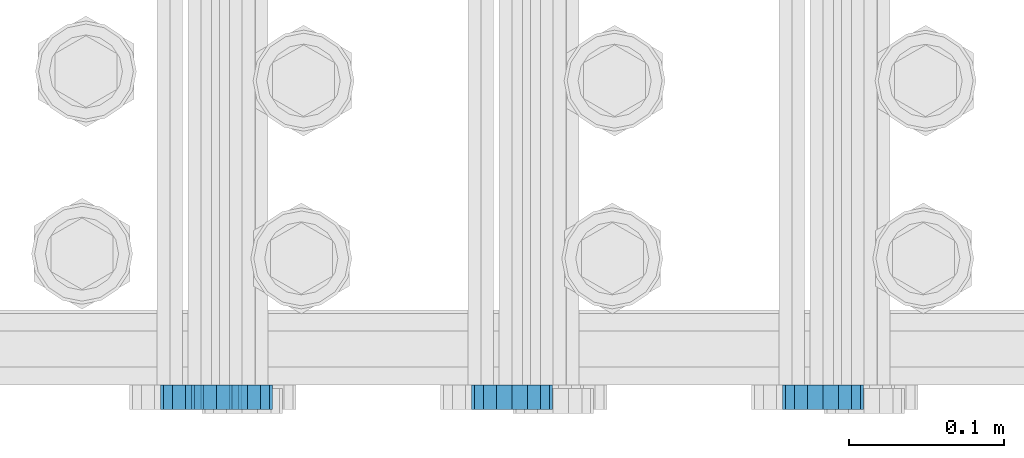
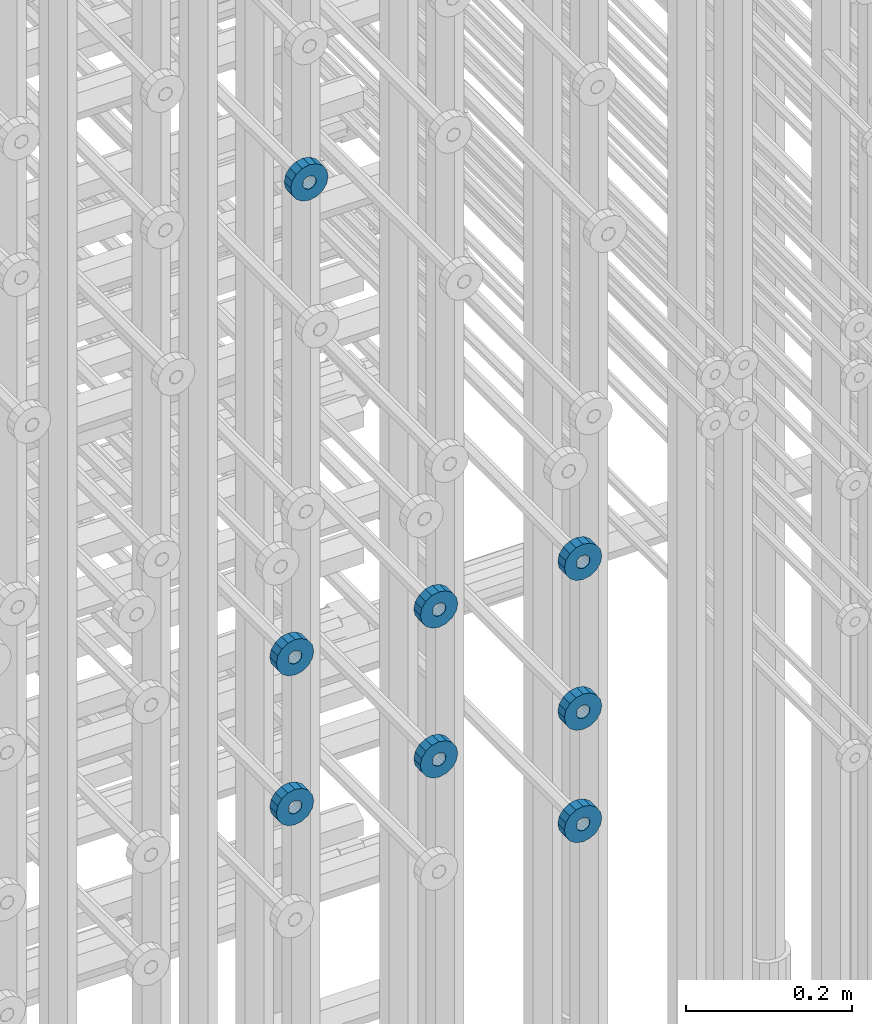
# One storey, part 125 of 177: 8 beams.
"""IFC2X3 building model written with IfcOpenShell, lengths in millimetres."""

from ifc_helpers import new_model, si_unit, frame, origin_with_axes, place, context, subcontext, project, spatial, faceted_brep, material, type_object, element, save


model = new_model("IFC2X3")

# Units and contexts
model_context_1 = context("Model", 3, precision=1e-05, world=origin_with_axes())
model_context_2 = context("Model", 3, precision=1e-05, world=origin_with_axes())
body_context = subcontext(model_context_2, "Body", "Model", "MODEL_VIEW")
ifc_project = project(units=[si_unit("LENGTHUNIT", "METRE", prefix="MILLI"), si_unit("AREAUNIT", "SQUARE_METRE"), si_unit("VOLUMEUNIT", "CUBIC_METRE"), si_unit("MASSUNIT", "GRAM", prefix="KILO"), si_unit("TIMEUNIT", "SECOND"), si_unit("PLANEANGLEUNIT", "RADIAN"), si_unit("SOLIDANGLEUNIT", "STERADIAN"), si_unit("THERMODYNAMICTEMPERATUREUNIT", "DEGREE_CELSIUS"), si_unit("LUMINOUSINTENSITYUNIT", "LUMEN")], contexts=[model_context_1])

# Site, building, storey
site_placement = place(None, origin_with_axes())
site = spatial("IfcSite", under=ifc_project, at=site_placement, CompositionType="ELEMENT")
building_placement = place(site_placement, origin_with_axes())
building = spatial("IfcBuilding", under=site, at=building_placement, Name="Undefined", CompositionType="ELEMENT")
storey_placement = place(building_placement, origin_with_axes())
storey = spatial("IfcBuildingStorey", under=building, at=storey_placement, Name="Undefined", CompositionType="ELEMENT", Elevation=0.0)

# Beams
ifc_material = material(Name="STEEL/Steel_Undefined")
beam_type = type_object("IfcBeamType", PredefinedType="NOTDEFINED")
beam_1_placement = place(storey_placement, frame((2030929.49847313, 6205075.98588576, 21349.9868126721), z_axis=(0.0, 0.0, -1.0), x_axis=(0.0, -1.0, 0.0)))
element("IfcBeam", 1, at=beam_1_placement, inside=storey, type_object=beam_type, material=ifc_material, context=body_context, shape_type="Brep", body=[
    faceted_brep([(0.0, -9.5, 0.0), (0.0, -8.77685555908829, 3.63549260746731), (16.0, -8.77685555908829, 3.63549260746731), (16.0, -9.5, 0.0), (0.0, -6.71751442085952, 6.71751442127061), (16.0, -6.71751442085952, 6.71751442127061), (0.0, -3.63549260701984, 8.77685555885546), (16.0, -3.63549260701984, 8.77685555885546), (-2.02452244836415e-12, 0.0, 9.5), (16.0, 0.0, 9.5), (0.0, 3.63549260701984, 8.77685555885546), (16.0, 3.63549260701984, 8.77685555885546), (0.0, 6.71751442085952, 6.71751442127061), (16.0, 6.71751442085952, 6.71751442127061), (0.0, 8.77685555908829, 3.63549260746731), (16.0, 8.77685555908829, 3.63549260746731), (0.0, 9.5, 0.0), (16.0, 9.5, 0.0), (0.0, 8.77685555908829, -3.63549260746731), (16.0, 8.77685555908829, -3.63549260746731), (0.0, 6.71751442085952, -6.71751442127061), (16.0, 6.71751442085952, -6.71751442127061), (0.0, 3.63549260701984, -8.77685555885546), (16.0, 3.63549260701984, -8.77685555885546), (2.02452244836415e-12, -3.69149155687865e-15, -9.5), (16.0, 0.0, -9.5), (0.0, -3.63549260701984, -8.77685555885546), (16.0, -3.63549260701984, -8.77685555885546), (0.0, -6.71751442085952, -6.71751442127061), (16.0, -6.71751442085952, -6.71751442127061), (0.0, -8.77685555908829, -3.63549260746731), (16.0, -8.77685555908829, -3.63549260746731), (0.0, -26.0, 0.0), (0.0, -24.0208678450435, -9.94976924149159), (16.0, -24.0208678450435, -9.94976924149159), (16.0, -26.0, 0.0), (0.0, -18.3847763109952, -18.3847763108497), (16.0, -18.3847763109952, -18.3847763108497), (0.0, -9.94976924173534, -24.0208678452946), (16.0, -9.94976924173534, -24.0208678452946), (0.0, 0.0, -26.0), (16.0, 0.0, -26.0), (0.0, 9.94976924173534, -24.0208678452946), (16.0, 9.94976924173534, -24.0208678452946), (0.0, 18.3847763109952, -18.3847763108497), (16.0, 18.3847763109952, -18.3847763108497), (0.0, 24.0208678450435, -9.94976924149159), (16.0, 24.0208678450435, -9.94976924149159), (0.0, 26.0, 0.0), (16.0, 26.0, 0.0), (0.0, 24.0208678450435, 9.94976924149159), (16.0, 24.0208678450435, 9.94976924149159), (0.0, 18.3847763109952, 18.3847763108497), (16.0, 18.3847763109952, 18.3847763108497), (0.0, 9.94976924173534, 24.0208678452946), (16.0, 9.94976924173534, 24.0208678452946), (0.0, 0.0, 26.0), (16.0, 0.0, 26.0), (0.0, -9.94976924173534, 24.0208678452946), (16.0, -9.94976924173534, 24.0208678452946), (0.0, -18.3847763109952, 18.3847763108497), (16.0, -18.3847763109952, 18.3847763108497), (0.0, -24.0208678450435, 9.94976924149159), (16.0, -24.0208678450435, 9.94976924149159)], [[[0, 1, 2, 3]], [[1, 4, 5, 2]], [[4, 6, 7, 5]], [[6, 8, 9, 7]], [[8, 10, 11, 9]], [[10, 12, 13, 11]], [[12, 14, 15, 13]], [[14, 16, 17, 15]], [[16, 18, 19, 17]], [[18, 20, 21, 19]], [[20, 22, 23, 21]], [[22, 24, 25, 23]], [[24, 26, 27, 25]], [[26, 28, 29, 27]], [[28, 30, 31, 29]], [[30, 0, 3, 31]], [[32, 33, 34, 35]], [[33, 36, 37, 34]], [[36, 38, 39, 37]], [[38, 40, 41, 39]], [[40, 42, 43, 41]], [[42, 44, 45, 43]], [[44, 46, 47, 45]], [[46, 48, 49, 47]], [[48, 50, 51, 49]], [[50, 52, 53, 51]], [[52, 54, 55, 53]], [[54, 56, 57, 55]], [[56, 58, 59, 57]], [[58, 60, 61, 59]], [[60, 62, 63, 61]], [[62, 32, 35, 63]], [[37, 39, 41, 43, 45, 47, 49, 51, 53, 55, 57, 59, 61, 63, 35, 34], [5, 7, 9, 11, 13, 15, 17, 19, 21, 23, 25, 27, 29, 31, 3, 2]], [[62, 60, 58, 56, 54, 52, 50, 48, 46, 44, 42, 40, 38, 36, 33, 32], [30, 28, 26, 24, 22, 20, 18, 16, 14, 12, 10, 8, 6, 4, 1, 0]]]),
])
beam_2_placement = place(storey_placement, frame((2031309.49847313, 6205075.98588034, 20659.9868114202), z_axis=(0.0, 0.0, -1.0), x_axis=(0.0, -1.0, 0.0)))
element("IfcBeam", 2, at=beam_2_placement, inside=storey, type_object=beam_type, material=ifc_material, context=body_context, shape_type="Brep", body=[
    faceted_brep([(0.0, -9.5, 0.0), (0.0, -8.77685555908829, 3.63549260746731), (16.0, -8.77685555908829, 3.63549260746731), (16.0, -9.5, 0.0), (0.0, -6.71751442085952, 6.71751442127061), (16.0, -6.71751442085952, 6.71751442127061), (0.0, -3.63549260701984, 8.77685555885546), (16.0, -3.63549260701984, 8.77685555885546), (-2.02452244836415e-12, 0.0, 9.5), (16.0, 0.0, 9.5), (0.0, 3.63549260701984, 8.77685555885546), (16.0, 3.63549260701984, 8.77685555885546), (0.0, 6.71751442085952, 6.71751442127061), (16.0, 6.71751442085952, 6.71751442127061), (0.0, 8.77685555908829, 3.63549260746731), (16.0, 8.77685555908829, 3.63549260746731), (0.0, 9.5, 0.0), (16.0, 9.5, 0.0), (0.0, 8.77685555908829, -3.63549260746731), (16.0, 8.77685555908829, -3.63549260746731), (0.0, 6.71751442085952, -6.71751442127061), (16.0, 6.71751442085952, -6.71751442127061), (0.0, 3.63549260701984, -8.77685555885546), (16.0, 3.63549260701984, -8.77685555885546), (2.02452244836415e-12, -3.69149155687865e-15, -9.5), (16.0, 0.0, -9.5), (0.0, -3.63549260701984, -8.77685555885546), (16.0, -3.63549260701984, -8.77685555885546), (0.0, -6.71751442085952, -6.71751442127061), (16.0, -6.71751442085952, -6.71751442127061), (0.0, -8.77685555908829, -3.63549260746731), (16.0, -8.77685555908829, -3.63549260746731), (0.0, -26.0, 0.0), (0.0, -24.0208678450435, -9.94976924149159), (16.0, -24.0208678450435, -9.94976924149159), (16.0, -26.0, 0.0), (0.0, -18.3847763109952, -18.3847763108497), (16.0, -18.3847763109952, -18.3847763108497), (0.0, -9.94976924173534, -24.0208678452946), (16.0, -9.94976924173534, -24.0208678452946), (0.0, 0.0, -26.0), (16.0, 0.0, -26.0), (0.0, 9.94976924173534, -24.0208678452946), (16.0, 9.94976924173534, -24.0208678452946), (0.0, 18.3847763109952, -18.3847763108497), (16.0, 18.3847763109952, -18.3847763108497), (0.0, 24.0208678450435, -9.94976924149159), (16.0, 24.0208678450435, -9.94976924149159), (0.0, 26.0, 0.0), (16.0, 26.0, 0.0), (0.0, 24.0208678450435, 9.94976924149159), (16.0, 24.0208678450435, 9.94976924149159), (0.0, 18.3847763109952, 18.3847763108497), (16.0, 18.3847763109952, 18.3847763108497), (0.0, 9.94976924173534, 24.0208678452946), (16.0, 9.94976924173534, 24.0208678452946), (0.0, 0.0, 26.0), (16.0, 0.0, 26.0), (0.0, -9.94976924173534, 24.0208678452946), (16.0, -9.94976924173534, 24.0208678452946), (0.0, -18.3847763109952, 18.3847763108497), (16.0, -18.3847763109952, 18.3847763108497), (0.0, -24.0208678450435, 9.94976924149159), (16.0, -24.0208678450435, 9.94976924149159)], [[[0, 1, 2, 3]], [[1, 4, 5, 2]], [[4, 6, 7, 5]], [[6, 8, 9, 7]], [[8, 10, 11, 9]], [[10, 12, 13, 11]], [[12, 14, 15, 13]], [[14, 16, 17, 15]], [[16, 18, 19, 17]], [[18, 20, 21, 19]], [[20, 22, 23, 21]], [[22, 24, 25, 23]], [[24, 26, 27, 25]], [[26, 28, 29, 27]], [[28, 30, 31, 29]], [[30, 0, 3, 31]], [[32, 33, 34, 35]], [[33, 36, 37, 34]], [[36, 38, 39, 37]], [[38, 40, 41, 39]], [[40, 42, 43, 41]], [[42, 44, 45, 43]], [[44, 46, 47, 45]], [[46, 48, 49, 47]], [[48, 50, 51, 49]], [[50, 52, 53, 51]], [[52, 54, 55, 53]], [[54, 56, 57, 55]], [[56, 58, 59, 57]], [[58, 60, 61, 59]], [[60, 62, 63, 61]], [[62, 32, 35, 63]], [[37, 39, 41, 43, 45, 47, 49, 51, 53, 55, 57, 59, 61, 63, 35, 34], [5, 7, 9, 11, 13, 15, 17, 19, 21, 23, 25, 27, 29, 31, 3, 2]], [[62, 60, 58, 56, 54, 52, 50, 48, 46, 44, 42, 40, 38, 36, 33, 32], [30, 28, 26, 24, 22, 20, 18, 16, 14, 12, 10, 8, 6, 4, 1, 0]]]),
])
beam_3_placement = place(storey_placement, frame((2031109.49847313, 6205075.98588034, 20659.9868114202), z_axis=(0.0, 0.0, -1.0), x_axis=(0.0, -1.0, 0.0)))
element("IfcBeam", 3, at=beam_3_placement, inside=storey, type_object=beam_type, material=ifc_material, context=body_context, shape_type="Brep", body=[
    faceted_brep([(0.0, -9.5, 0.0), (0.0, -8.77685555908829, 3.63549260746731), (16.0, -8.77685555908829, 3.63549260746731), (16.0, -9.5, 0.0), (0.0, -6.71751442085952, 6.71751442127061), (16.0, -6.71751442085952, 6.71751442127061), (0.0, -3.63549260701984, 8.77685555885546), (16.0, -3.63549260701984, 8.77685555885546), (-2.02452244836415e-12, 0.0, 9.5), (16.0, 0.0, 9.5), (0.0, 3.63549260701984, 8.77685555885546), (16.0, 3.63549260701984, 8.77685555885546), (0.0, 6.71751442085952, 6.71751442127061), (16.0, 6.71751442085952, 6.71751442127061), (0.0, 8.77685555908829, 3.63549260746731), (16.0, 8.77685555908829, 3.63549260746731), (0.0, 9.5, 0.0), (16.0, 9.5, 0.0), (0.0, 8.77685555908829, -3.63549260746731), (16.0, 8.77685555908829, -3.63549260746731), (0.0, 6.71751442085952, -6.71751442127061), (16.0, 6.71751442085952, -6.71751442127061), (0.0, 3.63549260701984, -8.77685555885546), (16.0, 3.63549260701984, -8.77685555885546), (2.02452244836415e-12, -3.69149155687865e-15, -9.5), (16.0, 0.0, -9.5), (0.0, -3.63549260701984, -8.77685555885546), (16.0, -3.63549260701984, -8.77685555885546), (0.0, -6.71751442085952, -6.71751442127061), (16.0, -6.71751442085952, -6.71751442127061), (0.0, -8.77685555908829, -3.63549260746731), (16.0, -8.77685555908829, -3.63549260746731), (0.0, -26.0, 0.0), (0.0, -24.0208678450435, -9.94976924149159), (16.0, -24.0208678450435, -9.94976924149159), (16.0, -26.0, 0.0), (0.0, -18.3847763109952, -18.3847763108497), (16.0, -18.3847763109952, -18.3847763108497), (0.0, -9.94976924173534, -24.0208678452946), (16.0, -9.94976924173534, -24.0208678452946), (0.0, 0.0, -26.0), (16.0, 0.0, -26.0), (0.0, 9.94976924173534, -24.0208678452946), (16.0, 9.94976924173534, -24.0208678452946), (0.0, 18.3847763109952, -18.3847763108497), (16.0, 18.3847763109952, -18.3847763108497), (0.0, 24.0208678450435, -9.94976924149159), (16.0, 24.0208678450435, -9.94976924149159), (0.0, 26.0, 0.0), (16.0, 26.0, 0.0), (0.0, 24.0208678450435, 9.94976924149159), (16.0, 24.0208678450435, 9.94976924149159), (0.0, 18.3847763109952, 18.3847763108497), (16.0, 18.3847763109952, 18.3847763108497), (0.0, 9.94976924173534, 24.0208678452946), (16.0, 9.94976924173534, 24.0208678452946), (0.0, 0.0, 26.0), (16.0, 0.0, 26.0), (0.0, -9.94976924173534, 24.0208678452946), (16.0, -9.94976924173534, 24.0208678452946), (0.0, -18.3847763109952, 18.3847763108497), (16.0, -18.3847763109952, 18.3847763108497), (0.0, -24.0208678450435, 9.94976924149159), (16.0, -24.0208678450435, 9.94976924149159)], [[[0, 1, 2, 3]], [[1, 4, 5, 2]], [[4, 6, 7, 5]], [[6, 8, 9, 7]], [[8, 10, 11, 9]], [[10, 12, 13, 11]], [[12, 14, 15, 13]], [[14, 16, 17, 15]], [[16, 18, 19, 17]], [[18, 20, 21, 19]], [[20, 22, 23, 21]], [[22, 24, 25, 23]], [[24, 26, 27, 25]], [[26, 28, 29, 27]], [[28, 30, 31, 29]], [[30, 0, 3, 31]], [[32, 33, 34, 35]], [[33, 36, 37, 34]], [[36, 38, 39, 37]], [[38, 40, 41, 39]], [[40, 42, 43, 41]], [[42, 44, 45, 43]], [[44, 46, 47, 45]], [[46, 48, 49, 47]], [[48, 50, 51, 49]], [[50, 52, 53, 51]], [[52, 54, 55, 53]], [[54, 56, 57, 55]], [[56, 58, 59, 57]], [[58, 60, 61, 59]], [[60, 62, 63, 61]], [[62, 32, 35, 63]], [[37, 39, 41, 43, 45, 47, 49, 51, 53, 55, 57, 59, 61, 63, 35, 34], [5, 7, 9, 11, 13, 15, 17, 19, 21, 23, 25, 27, 29, 31, 3, 2]], [[62, 60, 58, 56, 54, 52, 50, 48, 46, 44, 42, 40, 38, 36, 33, 32], [30, 28, 26, 24, 22, 20, 18, 16, 14, 12, 10, 8, 6, 4, 1, 0]]]),
])
beam_4_placement = place(storey_placement, frame((2030909.49847313, 6205075.98588034, 20659.9868114202), z_axis=(0.0, 0.0, -1.0), x_axis=(0.0, -1.0, 0.0)))
element("IfcBeam", 4, at=beam_4_placement, inside=storey, type_object=beam_type, material=ifc_material, context=body_context, shape_type="Brep", body=[
    faceted_brep([(0.0, -9.5, 0.0), (0.0, -8.77685555908829, 3.63549260746731), (16.0, -8.77685555908829, 3.63549260746731), (16.0, -9.5, 0.0), (0.0, -6.71751442085952, 6.71751442127061), (16.0, -6.71751442085952, 6.71751442127061), (0.0, -3.63549260701984, 8.77685555885546), (16.0, -3.63549260701984, 8.77685555885546), (-2.02452244836415e-12, 0.0, 9.5), (16.0, 0.0, 9.5), (0.0, 3.63549260701984, 8.77685555885546), (16.0, 3.63549260701984, 8.77685555885546), (0.0, 6.71751442085952, 6.71751442127061), (16.0, 6.71751442085952, 6.71751442127061), (0.0, 8.77685555908829, 3.63549260746731), (16.0, 8.77685555908829, 3.63549260746731), (0.0, 9.5, 0.0), (16.0, 9.5, 0.0), (0.0, 8.77685555908829, -3.63549260746731), (16.0, 8.77685555908829, -3.63549260746731), (0.0, 6.71751442085952, -6.71751442127061), (16.0, 6.71751442085952, -6.71751442127061), (0.0, 3.63549260701984, -8.77685555885546), (16.0, 3.63549260701984, -8.77685555885546), (2.02452244836415e-12, -3.69149155687865e-15, -9.5), (16.0, 0.0, -9.5), (0.0, -3.63549260701984, -8.77685555885546), (16.0, -3.63549260701984, -8.77685555885546), (0.0, -6.71751442085952, -6.71751442127061), (16.0, -6.71751442085952, -6.71751442127061), (0.0, -8.77685555908829, -3.63549260746731), (16.0, -8.77685555908829, -3.63549260746731), (0.0, -26.0, 0.0), (0.0, -24.0208678450435, -9.94976924149159), (16.0, -24.0208678450435, -9.94976924149159), (16.0, -26.0, 0.0), (0.0, -18.3847763109952, -18.3847763108497), (16.0, -18.3847763109952, -18.3847763108497), (0.0, -9.94976924173534, -24.0208678452946), (16.0, -9.94976924173534, -24.0208678452946), (0.0, 0.0, -26.0), (16.0, 0.0, -26.0), (0.0, 9.94976924173534, -24.0208678452946), (16.0, 9.94976924173534, -24.0208678452946), (0.0, 18.3847763109952, -18.3847763108497), (16.0, 18.3847763109952, -18.3847763108497), (0.0, 24.0208678450435, -9.94976924149159), (16.0, 24.0208678450435, -9.94976924149159), (0.0, 26.0, 0.0), (16.0, 26.0, 0.0), (0.0, 24.0208678450435, 9.94976924149159), (16.0, 24.0208678450435, 9.94976924149159), (0.0, 18.3847763109952, 18.3847763108497), (16.0, 18.3847763109952, 18.3847763108497), (0.0, 9.94976924173534, 24.0208678452946), (16.0, 9.94976924173534, 24.0208678452946), (0.0, 0.0, 26.0), (16.0, 0.0, 26.0), (0.0, -9.94976924173534, 24.0208678452946), (16.0, -9.94976924173534, 24.0208678452946), (0.0, -18.3847763109952, 18.3847763108497), (16.0, -18.3847763109952, 18.3847763108497), (0.0, -24.0208678450435, 9.94976924149159), (16.0, -24.0208678450435, 9.94976924149159)], [[[0, 1, 2, 3]], [[1, 4, 5, 2]], [[4, 6, 7, 5]], [[6, 8, 9, 7]], [[8, 10, 11, 9]], [[10, 12, 13, 11]], [[12, 14, 15, 13]], [[14, 16, 17, 15]], [[16, 18, 19, 17]], [[18, 20, 21, 19]], [[20, 22, 23, 21]], [[22, 24, 25, 23]], [[24, 26, 27, 25]], [[26, 28, 29, 27]], [[28, 30, 31, 29]], [[30, 0, 3, 31]], [[32, 33, 34, 35]], [[33, 36, 37, 34]], [[36, 38, 39, 37]], [[38, 40, 41, 39]], [[40, 42, 43, 41]], [[42, 44, 45, 43]], [[44, 46, 47, 45]], [[46, 48, 49, 47]], [[48, 50, 51, 49]], [[50, 52, 53, 51]], [[52, 54, 55, 53]], [[54, 56, 57, 55]], [[56, 58, 59, 57]], [[58, 60, 61, 59]], [[60, 62, 63, 61]], [[62, 32, 35, 63]], [[37, 39, 41, 43, 45, 47, 49, 51, 53, 55, 57, 59, 61, 63, 35, 34], [5, 7, 9, 11, 13, 15, 17, 19, 21, 23, 25, 27, 29, 31, 3, 2]], [[62, 60, 58, 56, 54, 52, 50, 48, 46, 44, 42, 40, 38, 36, 33, 32], [30, 28, 26, 24, 22, 20, 18, 16, 14, 12, 10, 8, 6, 4, 1, 0]]]),
])
beam_5_placement = place(storey_placement, frame((2031309.49847313, 6205075.98588033, 20439.9868114202), z_axis=(0.0, 0.0, -1.0), x_axis=(0.0, -1.0, 0.0)))
element("IfcBeam", 5, at=beam_5_placement, inside=storey, type_object=beam_type, material=ifc_material, context=body_context, shape_type="Brep", body=[
    faceted_brep([(0.0, -9.5, 0.0), (0.0, -8.77685555908829, 3.63549260746731), (16.0, -8.77685555908829, 3.63549260746731), (16.0, -9.5, 0.0), (0.0, -6.71751442085952, 6.71751442127061), (16.0, -6.71751442085952, 6.71751442127061), (0.0, -3.63549260701984, 8.77685555885546), (16.0, -3.63549260701984, 8.77685555885546), (-2.02452244836415e-12, 0.0, 9.5), (16.0, 0.0, 9.5), (0.0, 3.63549260701984, 8.77685555885546), (16.0, 3.63549260701984, 8.77685555885546), (0.0, 6.71751442085952, 6.71751442127061), (16.0, 6.71751442085952, 6.71751442127061), (0.0, 8.77685555908829, 3.63549260746731), (16.0, 8.77685555908829, 3.63549260746731), (0.0, 9.5, 0.0), (16.0, 9.5, 0.0), (0.0, 8.77685555908829, -3.63549260746731), (16.0, 8.77685555908829, -3.63549260746731), (0.0, 6.71751442085952, -6.71751442127061), (16.0, 6.71751442085952, -6.71751442127061), (0.0, 3.63549260701984, -8.77685555885546), (16.0, 3.63549260701984, -8.77685555885546), (2.02452244836415e-12, -3.69149155687865e-15, -9.5), (16.0, 0.0, -9.5), (0.0, -3.63549260701984, -8.77685555885546), (16.0, -3.63549260701984, -8.77685555885546), (0.0, -6.71751442085952, -6.71751442127061), (16.0, -6.71751442085952, -6.71751442127061), (0.0, -8.77685555908829, -3.63549260746731), (16.0, -8.77685555908829, -3.63549260746731), (0.0, -26.0, 0.0), (0.0, -24.0208678450435, -9.94976924149159), (16.0, -24.0208678450435, -9.94976924149159), (16.0, -26.0, 0.0), (0.0, -18.3847763109952, -18.3847763108497), (16.0, -18.3847763109952, -18.3847763108497), (0.0, -9.94976924173534, -24.0208678452946), (16.0, -9.94976924173534, -24.0208678452946), (0.0, 0.0, -26.0), (16.0, 0.0, -26.0), (0.0, 9.94976924173534, -24.0208678452946), (16.0, 9.94976924173534, -24.0208678452946), (0.0, 18.3847763109952, -18.3847763108497), (16.0, 18.3847763109952, -18.3847763108497), (0.0, 24.0208678450435, -9.94976924149159), (16.0, 24.0208678450435, -9.94976924149159), (0.0, 26.0, 0.0), (16.0, 26.0, 0.0), (0.0, 24.0208678450435, 9.94976924149159), (16.0, 24.0208678450435, 9.94976924149159), (0.0, 18.3847763109952, 18.3847763108497), (16.0, 18.3847763109952, 18.3847763108497), (0.0, 9.94976924173534, 24.0208678452946), (16.0, 9.94976924173534, 24.0208678452946), (0.0, 0.0, 26.0), (16.0, 0.0, 26.0), (0.0, -9.94976924173534, 24.0208678452946), (16.0, -9.94976924173534, 24.0208678452946), (0.0, -18.3847763109952, 18.3847763108497), (16.0, -18.3847763109952, 18.3847763108497), (0.0, -24.0208678450435, 9.94976924149159), (16.0, -24.0208678450435, 9.94976924149159)], [[[0, 1, 2, 3]], [[1, 4, 5, 2]], [[4, 6, 7, 5]], [[6, 8, 9, 7]], [[8, 10, 11, 9]], [[10, 12, 13, 11]], [[12, 14, 15, 13]], [[14, 16, 17, 15]], [[16, 18, 19, 17]], [[18, 20, 21, 19]], [[20, 22, 23, 21]], [[22, 24, 25, 23]], [[24, 26, 27, 25]], [[26, 28, 29, 27]], [[28, 30, 31, 29]], [[30, 0, 3, 31]], [[32, 33, 34, 35]], [[33, 36, 37, 34]], [[36, 38, 39, 37]], [[38, 40, 41, 39]], [[40, 42, 43, 41]], [[42, 44, 45, 43]], [[44, 46, 47, 45]], [[46, 48, 49, 47]], [[48, 50, 51, 49]], [[50, 52, 53, 51]], [[52, 54, 55, 53]], [[54, 56, 57, 55]], [[56, 58, 59, 57]], [[58, 60, 61, 59]], [[60, 62, 63, 61]], [[62, 32, 35, 63]], [[37, 39, 41, 43, 45, 47, 49, 51, 53, 55, 57, 59, 61, 63, 35, 34], [5, 7, 9, 11, 13, 15, 17, 19, 21, 23, 25, 27, 29, 31, 3, 2]], [[62, 60, 58, 56, 54, 52, 50, 48, 46, 44, 42, 40, 38, 36, 33, 32], [30, 28, 26, 24, 22, 20, 18, 16, 14, 12, 10, 8, 6, 4, 1, 0]]]),
])
beam_6_placement = place(storey_placement, frame((2031109.49847313, 6205075.98588033, 20439.9868114202), z_axis=(0.0, 0.0, -1.0), x_axis=(0.0, -1.0, 0.0)))
element("IfcBeam", 6, at=beam_6_placement, inside=storey, type_object=beam_type, material=ifc_material, context=body_context, shape_type="Brep", body=[
    faceted_brep([(0.0, -9.5, 0.0), (0.0, -8.77685555908829, 3.63549260746731), (16.0, -8.77685555908829, 3.63549260746731), (16.0, -9.5, 0.0), (0.0, -6.71751442085952, 6.71751442127061), (16.0, -6.71751442085952, 6.71751442127061), (0.0, -3.63549260701984, 8.77685555885546), (16.0, -3.63549260701984, 8.77685555885546), (-2.02452244836415e-12, 0.0, 9.5), (16.0, 0.0, 9.5), (0.0, 3.63549260701984, 8.77685555885546), (16.0, 3.63549260701984, 8.77685555885546), (0.0, 6.71751442085952, 6.71751442127061), (16.0, 6.71751442085952, 6.71751442127061), (0.0, 8.77685555908829, 3.63549260746731), (16.0, 8.77685555908829, 3.63549260746731), (0.0, 9.5, 0.0), (16.0, 9.5, 0.0), (0.0, 8.77685555908829, -3.63549260746731), (16.0, 8.77685555908829, -3.63549260746731), (0.0, 6.71751442085952, -6.71751442127061), (16.0, 6.71751442085952, -6.71751442127061), (0.0, 3.63549260701984, -8.77685555885546), (16.0, 3.63549260701984, -8.77685555885546), (2.02452244836415e-12, -3.69149155687865e-15, -9.5), (16.0, 0.0, -9.5), (0.0, -3.63549260701984, -8.77685555885546), (16.0, -3.63549260701984, -8.77685555885546), (0.0, -6.71751442085952, -6.71751442127061), (16.0, -6.71751442085952, -6.71751442127061), (0.0, -8.77685555908829, -3.63549260746731), (16.0, -8.77685555908829, -3.63549260746731), (0.0, -26.0, 0.0), (0.0, -24.0208678450435, -9.94976924149159), (16.0, -24.0208678450435, -9.94976924149159), (16.0, -26.0, 0.0), (0.0, -18.3847763109952, -18.3847763108497), (16.0, -18.3847763109952, -18.3847763108497), (0.0, -9.94976924173534, -24.0208678452946), (16.0, -9.94976924173534, -24.0208678452946), (0.0, 0.0, -26.0), (16.0, 0.0, -26.0), (0.0, 9.94976924173534, -24.0208678452946), (16.0, 9.94976924173534, -24.0208678452946), (0.0, 18.3847763109952, -18.3847763108497), (16.0, 18.3847763109952, -18.3847763108497), (0.0, 24.0208678450435, -9.94976924149159), (16.0, 24.0208678450435, -9.94976924149159), (0.0, 26.0, 0.0), (16.0, 26.0, 0.0), (0.0, 24.0208678450435, 9.94976924149159), (16.0, 24.0208678450435, 9.94976924149159), (0.0, 18.3847763109952, 18.3847763108497), (16.0, 18.3847763109952, 18.3847763108497), (0.0, 9.94976924173534, 24.0208678452946), (16.0, 9.94976924173534, 24.0208678452946), (0.0, 0.0, 26.0), (16.0, 0.0, 26.0), (0.0, -9.94976924173534, 24.0208678452946), (16.0, -9.94976924173534, 24.0208678452946), (0.0, -18.3847763109952, 18.3847763108497), (16.0, -18.3847763109952, 18.3847763108497), (0.0, -24.0208678450435, 9.94976924149159), (16.0, -24.0208678450435, 9.94976924149159)], [[[0, 1, 2, 3]], [[1, 4, 5, 2]], [[4, 6, 7, 5]], [[6, 8, 9, 7]], [[8, 10, 11, 9]], [[10, 12, 13, 11]], [[12, 14, 15, 13]], [[14, 16, 17, 15]], [[16, 18, 19, 17]], [[18, 20, 21, 19]], [[20, 22, 23, 21]], [[22, 24, 25, 23]], [[24, 26, 27, 25]], [[26, 28, 29, 27]], [[28, 30, 31, 29]], [[30, 0, 3, 31]], [[32, 33, 34, 35]], [[33, 36, 37, 34]], [[36, 38, 39, 37]], [[38, 40, 41, 39]], [[40, 42, 43, 41]], [[42, 44, 45, 43]], [[44, 46, 47, 45]], [[46, 48, 49, 47]], [[48, 50, 51, 49]], [[50, 52, 53, 51]], [[52, 54, 55, 53]], [[54, 56, 57, 55]], [[56, 58, 59, 57]], [[58, 60, 61, 59]], [[60, 62, 63, 61]], [[62, 32, 35, 63]], [[37, 39, 41, 43, 45, 47, 49, 51, 53, 55, 57, 59, 61, 63, 35, 34], [5, 7, 9, 11, 13, 15, 17, 19, 21, 23, 25, 27, 29, 31, 3, 2]], [[62, 60, 58, 56, 54, 52, 50, 48, 46, 44, 42, 40, 38, 36, 33, 32], [30, 28, 26, 24, 22, 20, 18, 16, 14, 12, 10, 8, 6, 4, 1, 0]]]),
])
beam_7_placement = place(storey_placement, frame((2030909.49847313, 6205075.98588033, 20439.9868114202), z_axis=(0.0, 0.0, -1.0), x_axis=(0.0, -1.0, 0.0)))
element("IfcBeam", 7, at=beam_7_placement, inside=storey, type_object=beam_type, material=ifc_material, context=body_context, shape_type="Brep", body=[
    faceted_brep([(0.0, -9.5, 0.0), (0.0, -8.77685555908829, 3.63549260746731), (16.0, -8.77685555908829, 3.63549260746731), (16.0, -9.5, 0.0), (0.0, -6.71751442085952, 6.71751442127061), (16.0, -6.71751442085952, 6.71751442127061), (0.0, -3.63549260701984, 8.77685555885546), (16.0, -3.63549260701984, 8.77685555885546), (-2.02452244836415e-12, 0.0, 9.5), (16.0, 0.0, 9.5), (0.0, 3.63549260701984, 8.77685555885546), (16.0, 3.63549260701984, 8.77685555885546), (0.0, 6.71751442085952, 6.71751442127061), (16.0, 6.71751442085952, 6.71751442127061), (0.0, 8.77685555908829, 3.63549260746731), (16.0, 8.77685555908829, 3.63549260746731), (0.0, 9.5, 0.0), (16.0, 9.5, 0.0), (0.0, 8.77685555908829, -3.63549260746731), (16.0, 8.77685555908829, -3.63549260746731), (0.0, 6.71751442085952, -6.71751442127061), (16.0, 6.71751442085952, -6.71751442127061), (0.0, 3.63549260701984, -8.77685555885546), (16.0, 3.63549260701984, -8.77685555885546), (2.02452244836415e-12, -3.69149155687865e-15, -9.5), (16.0, 0.0, -9.5), (0.0, -3.63549260701984, -8.77685555885546), (16.0, -3.63549260701984, -8.77685555885546), (0.0, -6.71751442085952, -6.71751442127061), (16.0, -6.71751442085952, -6.71751442127061), (0.0, -8.77685555908829, -3.63549260746731), (16.0, -8.77685555908829, -3.63549260746731), (0.0, -26.0, 0.0), (0.0, -24.0208678450435, -9.94976924149159), (16.0, -24.0208678450435, -9.94976924149159), (16.0, -26.0, 0.0), (0.0, -18.3847763109952, -18.3847763108497), (16.0, -18.3847763109952, -18.3847763108497), (0.0, -9.94976924173534, -24.0208678452946), (16.0, -9.94976924173534, -24.0208678452946), (0.0, 0.0, -26.0), (16.0, 0.0, -26.0), (0.0, 9.94976924173534, -24.0208678452946), (16.0, 9.94976924173534, -24.0208678452946), (0.0, 18.3847763109952, -18.3847763108497), (16.0, 18.3847763109952, -18.3847763108497), (0.0, 24.0208678450435, -9.94976924149159), (16.0, 24.0208678450435, -9.94976924149159), (0.0, 26.0, 0.0), (16.0, 26.0, 0.0), (0.0, 24.0208678450435, 9.94976924149159), (16.0, 24.0208678450435, 9.94976924149159), (0.0, 18.3847763109952, 18.3847763108497), (16.0, 18.3847763109952, 18.3847763108497), (0.0, 9.94976924173534, 24.0208678452946), (16.0, 9.94976924173534, 24.0208678452946), (0.0, 0.0, 26.0), (16.0, 0.0, 26.0), (0.0, -9.94976924173534, 24.0208678452946), (16.0, -9.94976924173534, 24.0208678452946), (0.0, -18.3847763109952, 18.3847763108497), (16.0, -18.3847763109952, 18.3847763108497), (0.0, -24.0208678450435, 9.94976924149159), (16.0, -24.0208678450435, 9.94976924149159)], [[[0, 1, 2, 3]], [[1, 4, 5, 2]], [[4, 6, 7, 5]], [[6, 8, 9, 7]], [[8, 10, 11, 9]], [[10, 12, 13, 11]], [[12, 14, 15, 13]], [[14, 16, 17, 15]], [[16, 18, 19, 17]], [[18, 20, 21, 19]], [[20, 22, 23, 21]], [[22, 24, 25, 23]], [[24, 26, 27, 25]], [[26, 28, 29, 27]], [[28, 30, 31, 29]], [[30, 0, 3, 31]], [[32, 33, 34, 35]], [[33, 36, 37, 34]], [[36, 38, 39, 37]], [[38, 40, 41, 39]], [[40, 42, 43, 41]], [[42, 44, 45, 43]], [[44, 46, 47, 45]], [[46, 48, 49, 47]], [[48, 50, 51, 49]], [[50, 52, 53, 51]], [[52, 54, 55, 53]], [[54, 56, 57, 55]], [[56, 58, 59, 57]], [[58, 60, 61, 59]], [[60, 62, 63, 61]], [[62, 32, 35, 63]], [[37, 39, 41, 43, 45, 47, 49, 51, 53, 55, 57, 59, 61, 63, 35, 34], [5, 7, 9, 11, 13, 15, 17, 19, 21, 23, 25, 27, 29, 31, 3, 2]], [[62, 60, 58, 56, 54, 52, 50, 48, 46, 44, 42, 40, 38, 36, 33, 32], [30, 28, 26, 24, 22, 20, 18, 16, 14, 12, 10, 8, 6, 4, 1, 0]]]),
])
beam_8_placement = place(storey_placement, frame((2031309.49847313, 6205075.98588034, 20274.9868114202), z_axis=(0.0, 0.0, -1.0), x_axis=(0.0, -1.0, 0.0)))
element("IfcBeam", 8, at=beam_8_placement, inside=storey, type_object=beam_type, material=ifc_material, context=body_context, shape_type="Brep", body=[
    faceted_brep([(0.0, -9.5, 0.0), (0.0, -8.77685555908829, 3.63549260746731), (16.0, -8.77685555908829, 3.63549260746731), (16.0, -9.5, 0.0), (0.0, -6.71751442085952, 6.71751442127061), (16.0, -6.71751442085952, 6.71751442127061), (0.0, -3.63549260701984, 8.77685555885546), (16.0, -3.63549260701984, 8.77685555885546), (-2.02452244836415e-12, 0.0, 9.5), (16.0, 0.0, 9.5), (0.0, 3.63549260701984, 8.77685555885546), (16.0, 3.63549260701984, 8.77685555885546), (0.0, 6.71751442085952, 6.71751442127061), (16.0, 6.71751442085952, 6.71751442127061), (0.0, 8.77685555908829, 3.63549260746731), (16.0, 8.77685555908829, 3.63549260746731), (0.0, 9.5, 0.0), (16.0, 9.5, 0.0), (0.0, 8.77685555908829, -3.63549260746731), (16.0, 8.77685555908829, -3.63549260746731), (0.0, 6.71751442085952, -6.71751442127061), (16.0, 6.71751442085952, -6.71751442127061), (0.0, 3.63549260701984, -8.77685555885546), (16.0, 3.63549260701984, -8.77685555885546), (2.02452244836415e-12, -3.69149155687865e-15, -9.5), (16.0, 0.0, -9.5), (0.0, -3.63549260701984, -8.77685555885546), (16.0, -3.63549260701984, -8.77685555885546), (0.0, -6.71751442085952, -6.71751442127061), (16.0, -6.71751442085952, -6.71751442127061), (0.0, -8.77685555908829, -3.63549260746731), (16.0, -8.77685555908829, -3.63549260746731), (0.0, -26.0, 0.0), (0.0, -24.0208678450435, -9.94976924149159), (16.0, -24.0208678450435, -9.94976924149159), (16.0, -26.0, 0.0), (0.0, -18.3847763109952, -18.3847763108497), (16.0, -18.3847763109952, -18.3847763108497), (0.0, -9.94976924173534, -24.0208678452946), (16.0, -9.94976924173534, -24.0208678452946), (0.0, 0.0, -26.0), (16.0, 0.0, -26.0), (0.0, 9.94976924173534, -24.0208678452946), (16.0, 9.94976924173534, -24.0208678452946), (0.0, 18.3847763109952, -18.3847763108497), (16.0, 18.3847763109952, -18.3847763108497), (0.0, 24.0208678450435, -9.94976924149159), (16.0, 24.0208678450435, -9.94976924149159), (0.0, 26.0, 0.0), (16.0, 26.0, 0.0), (0.0, 24.0208678450435, 9.94976924149159), (16.0, 24.0208678450435, 9.94976924149159), (0.0, 18.3847763109952, 18.3847763108497), (16.0, 18.3847763109952, 18.3847763108497), (0.0, 9.94976924173534, 24.0208678452946), (16.0, 9.94976924173534, 24.0208678452946), (0.0, 0.0, 26.0), (16.0, 0.0, 26.0), (0.0, -9.94976924173534, 24.0208678452946), (16.0, -9.94976924173534, 24.0208678452946), (0.0, -18.3847763109952, 18.3847763108497), (16.0, -18.3847763109952, 18.3847763108497), (0.0, -24.0208678450435, 9.94976924149159), (16.0, -24.0208678450435, 9.94976924149159)], [[[0, 1, 2, 3]], [[1, 4, 5, 2]], [[4, 6, 7, 5]], [[6, 8, 9, 7]], [[8, 10, 11, 9]], [[10, 12, 13, 11]], [[12, 14, 15, 13]], [[14, 16, 17, 15]], [[16, 18, 19, 17]], [[18, 20, 21, 19]], [[20, 22, 23, 21]], [[22, 24, 25, 23]], [[24, 26, 27, 25]], [[26, 28, 29, 27]], [[28, 30, 31, 29]], [[30, 0, 3, 31]], [[32, 33, 34, 35]], [[33, 36, 37, 34]], [[36, 38, 39, 37]], [[38, 40, 41, 39]], [[40, 42, 43, 41]], [[42, 44, 45, 43]], [[44, 46, 47, 45]], [[46, 48, 49, 47]], [[48, 50, 51, 49]], [[50, 52, 53, 51]], [[52, 54, 55, 53]], [[54, 56, 57, 55]], [[56, 58, 59, 57]], [[58, 60, 61, 59]], [[60, 62, 63, 61]], [[62, 32, 35, 63]], [[37, 39, 41, 43, 45, 47, 49, 51, 53, 55, 57, 59, 61, 63, 35, 34], [5, 7, 9, 11, 13, 15, 17, 19, 21, 23, 25, 27, 29, 31, 3, 2]], [[62, 60, 58, 56, 54, 52, 50, 48, 46, 44, 42, 40, 38, 36, 33, 32], [30, 28, 26, 24, 22, 20, 18, 16, 14, 12, 10, 8, 6, 4, 1, 0]]]),
])

save(model, "model.ifc")
